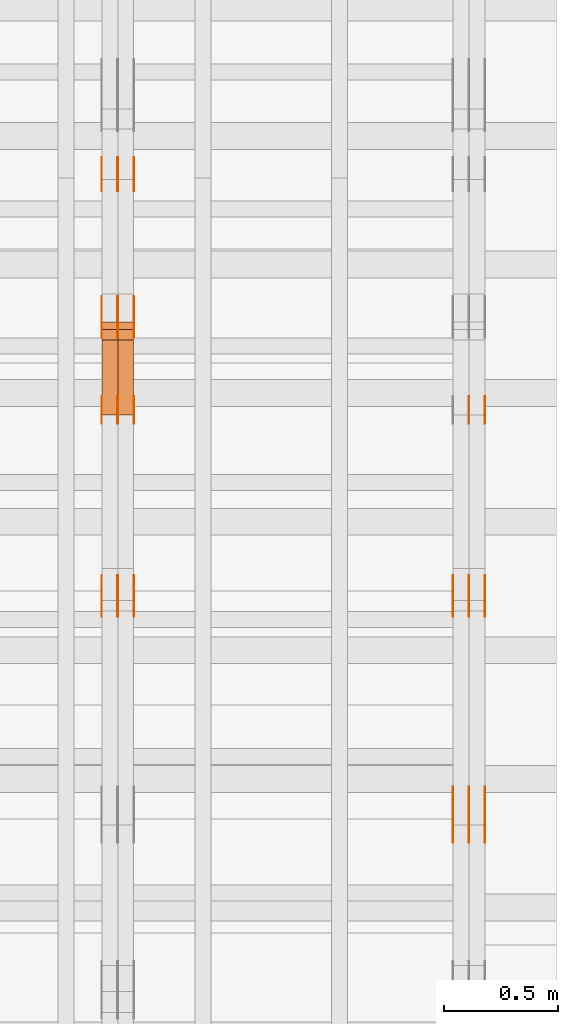
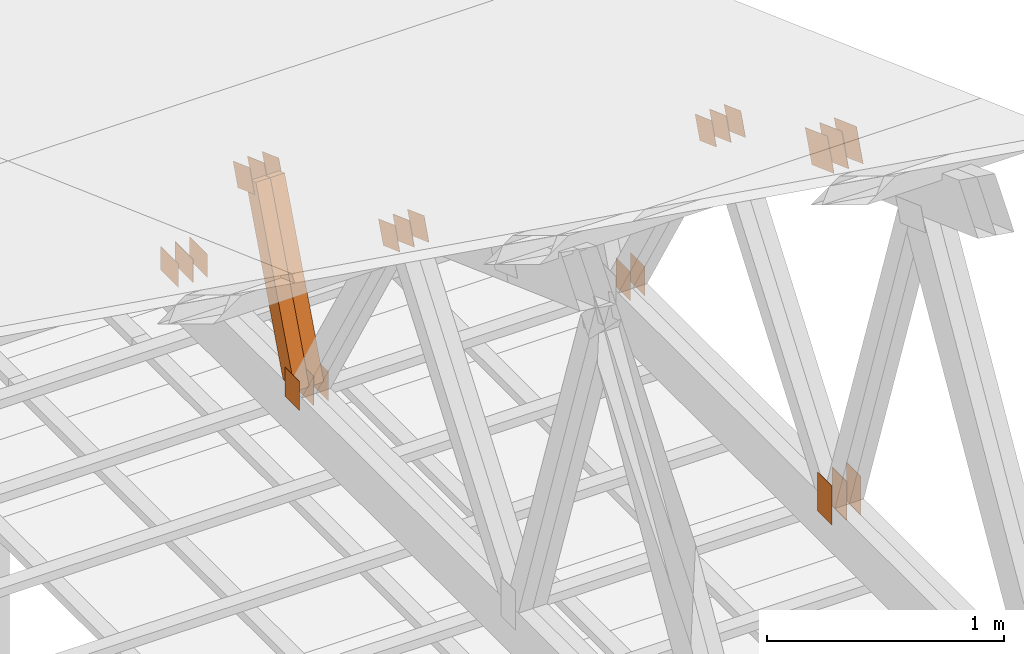
# One storey, part 176 of 189: 32 proxies.
"""IFC2X3 building model written with IfcOpenShell, lengths in millimetres."""

from ifc_helpers import new_model, entity, si_unit, converted_unit, derived_unit, direction, frame, frame_2d, origin, origin_2d_with_axis, place, context, subcontext, project, spatial, polyline, rectangle, outline, extrude, source, transform, mapped, material, type_object, type_shapes, element, save


model = new_model("IFC2X3")

# Units and contexts
model_context = context("Model", 3, precision=0.01, world=origin(), true_north=direction((6.12303176911189e-17, 1.0)))
body_context = subcontext(model_context, "Body", "Model", "MODEL_VIEW")
ifc_project = project(units=[si_unit("LENGTHUNIT", "METRE", prefix="MILLI"), si_unit("AREAUNIT", "SQUARE_METRE"), si_unit("VOLUMEUNIT", "CUBIC_METRE"), converted_unit("PLANEANGLEUNIT", "DEGREE", entity("IfcRatioMeasure", 0.0174532925199433), si_unit("PLANEANGLEUNIT", "RADIAN"), dimensions=[0, 0, 0, 0, 0, 0, 0]), si_unit("MASSUNIT", "GRAM", prefix="KILO"), derived_unit("MASSDENSITYUNIT", [(si_unit("MASSUNIT", "GRAM", prefix="KILO"), 1), (si_unit("LENGTHUNIT", "METRE"), -3)]), si_unit("TIMEUNIT", "SECOND"), si_unit("FREQUENCYUNIT", "HERTZ"), si_unit("THERMODYNAMICTEMPERATUREUNIT", "DEGREE_CELSIUS"), derived_unit("THERMALTRANSMITTANCEUNIT", [(si_unit("MASSUNIT", "GRAM", prefix="KILO"), 1), (si_unit("THERMODYNAMICTEMPERATUREUNIT", "KELVIN"), -1), (si_unit("TIMEUNIT", "SECOND"), -3)]), derived_unit("VOLUMETRICFLOWRATEUNIT", [(si_unit("LENGTHUNIT", "METRE"), 3), (si_unit("TIMEUNIT", "SECOND"), -1)]), si_unit("ELECTRICCURRENTUNIT", "AMPERE"), si_unit("ELECTRICVOLTAGEUNIT", "VOLT"), si_unit("POWERUNIT", "WATT"), si_unit("FORCEUNIT", "NEWTON"), si_unit("ILLUMINANCEUNIT", "LUX"), si_unit("LUMINOUSFLUXUNIT", "LUMEN"), si_unit("LUMINOUSINTENSITYUNIT", "CANDELA"), derived_unit("USERDEFINED", [(si_unit("MASSUNIT", "GRAM", prefix="KILO"), -1), (si_unit("LENGTHUNIT", "METRE"), -2), (si_unit("TIMEUNIT", "SECOND"), 3), (si_unit("LUMINOUSFLUXUNIT", "LUMEN"), 1)]), derived_unit("LINEARVELOCITYUNIT", [(si_unit("LENGTHUNIT", "METRE"), 1), (si_unit("TIMEUNIT", "SECOND"), -1)]), si_unit("PRESSUREUNIT", "PASCAL"), derived_unit("USERDEFINED", [(si_unit("LENGTHUNIT", "METRE"), -2), (si_unit("MASSUNIT", "GRAM", prefix="KILO"), 1), (si_unit("TIMEUNIT", "SECOND"), -2)])], contexts=[model_context])

# Site, building, storey
site_placement = place(None, origin())
site = spatial("IfcSite", under=ifc_project, at=site_placement, CompositionType="ELEMENT")
building_placement = place(site_placement, origin())
building = spatial("IfcBuilding", under=site, at=building_placement, CompositionType="ELEMENT")
storey_placement = place(building_placement, origin())
storey = spatial("IfcBuildingStorey", under=building, at=storey_placement, Name="Default", CompositionType="ELEMENT", Elevation=0.0)

# Proxies
ifc_material_1 = material(Name="IfcSurfaceStyle #279940")
building_element_proxy_type_1 = type_object("IfcBuildingElementProxyType", PredefinedType="NOTDEFINED", material=ifc_material_1)
shared_shape_1 = source(origin(), body_context, "Body", "SweptSolid", [
    extrude(rectangle(XDim=200.0, YDim=120.0, at=origin_2d_with_axis()), frame((100.0, 60.0002296775929, 0.0), z_axis=(0.0, 0.0, 1.0), x_axis=(-1.0, 0.0, 0.0)), (0.0, 0.0, 1.0), 1.3),
])
type_shapes(building_element_proxy_type_1, [shared_shape_1])
proxy_1_placement = place(building_placement, frame((49841.3, 24619.3435203224, 145.0), z_axis=(-1.0, 0.0, 0.0), x_axis=(0.0, 0.0, 1.0)))
element("IfcBuildingElementProxy", 1, at=proxy_1_placement, inside=storey, type_object=building_element_proxy_type_1, material=ifc_material_1, context=body_context, shape_type="MappedRepresentation", body=[
    mapped(shared_shape_1, transform((0.0, 0.0, 0.0), scale=1.0)),
])
ifc_material_2 = material(Name="IfcSurfaceStyle #279883")
building_element_proxy_type_2 = type_object("IfcBuildingElementProxyType", PredefinedType="NOTDEFINED", material=ifc_material_2)
shared_shape_2 = source(origin(), body_context, "Body", "SweptSolid", [
    extrude(rectangle(XDim=200.0, YDim=120.0, at=origin_2d_with_axis()), frame((100.0, 60.0002296775929, 0.0), z_axis=(0.0, 0.0, 1.0), x_axis=(-1.0, 0.0, 0.0)), (0.0, 0.0, 1.0), 1.29999999999998),
])
type_shapes(building_element_proxy_type_2, [shared_shape_2])
proxy_2_placement = place(building_placement, frame((49770.0, 24619.3435203224, 145.0), z_axis=(-1.0, 0.0, 0.0), x_axis=(0.0, 0.0, 1.0)))
element("IfcBuildingElementProxy", 2, at=proxy_2_placement, inside=storey, type_object=building_element_proxy_type_2, material=ifc_material_2, context=body_context, shape_type="MappedRepresentation", body=[
    mapped(shared_shape_2, transform((0.0, 0.0, 0.0), scale=1.0)),
])
ifc_material_3 = material(Name="IfcSurfaceStyle #279826")
building_element_proxy_type_3 = type_object("IfcBuildingElementProxyType", PredefinedType="NOTDEFINED", material=ifc_material_3)
shared_shape_3 = source(origin(), body_context, "Body", "SweptSolid", [
    extrude(rectangle(XDim=200.0, YDim=120.0, at=origin_2d_with_axis()), frame((100.0, 60.0002296775929, 0.0), z_axis=(0.0, 0.0, 1.0), x_axis=(-1.0, 0.0, 0.0)), (0.0, 0.0, 1.0), 1.29999999999998),
])
type_shapes(building_element_proxy_type_3, [shared_shape_3])
proxy_3_placement = place(building_placement, frame((49771.3, 24619.3435203224, 145.0), z_axis=(-1.0, 0.0, 0.0), x_axis=(0.0, 0.0, 1.0)))
element("IfcBuildingElementProxy", 3, at=proxy_3_placement, inside=storey, type_object=building_element_proxy_type_3, material=ifc_material_3, context=body_context, shape_type="MappedRepresentation", body=[
    mapped(shared_shape_3, transform((0.0, 0.0, 0.0), scale=1.0)),
])
ifc_material_4 = material(Name="IfcSurfaceStyle #279769")
building_element_proxy_type_4 = type_object("IfcBuildingElementProxyType", PredefinedType="NOTDEFINED", material=ifc_material_4)
shared_shape_4 = source(origin(), body_context, "Body", "SweptSolid", [
    extrude(rectangle(XDim=200.0, YDim=120.0, at=origin_2d_with_axis()), frame((100.0, 60.0002296775929, 0.0), z_axis=(0.0, 0.0, 1.0), x_axis=(-1.0, 0.0, 0.0)), (0.0, 0.0, 1.0), 1.29999999999999),
])
type_shapes(building_element_proxy_type_4, [shared_shape_4])
proxy_4_placement = place(building_placement, frame((49700.0, 24619.3435203224, 145.0), z_axis=(-1.0, 0.0, 0.0), x_axis=(0.0, 0.0, 1.0)))
element("IfcBuildingElementProxy", 4, at=proxy_4_placement, inside=storey, type_object=building_element_proxy_type_4, material=ifc_material_4, context=body_context, shape_type="MappedRepresentation", body=[
    mapped(shared_shape_4, transform((0.0, 0.0, 0.0), scale=1.0)),
])
ifc_material_5 = material(Name="IfcSurfaceStyle #279256")
building_element_proxy_type_5 = type_object("IfcBuildingElementProxyType", PredefinedType="NOTDEFINED", material=ifc_material_5)
shared_shape_5 = source(origin(), body_context, "Body", "SweptSolid", [
    extrude(outline(polyline([(-74.9999475298494, -60.0), (75.0000042257432, -60.0), (74.9999684051025, 60.0), (-75.0000251009963, 60.0), (-74.9999475298494, -60.0)])), frame((75.0000607644577, 60.0000865490217, 0.0), z_axis=(0.0, 0.0, 1.0), x_axis=(-1.0, 0.0, 0.0)), (0.0, 0.0, 1.0), 1.3),
])
type_shapes(building_element_proxy_type_5, [shared_shape_5])
proxy_5_placement = place(building_placement, frame((49841.3, 25732.0586805394, 1446.84420669249), z_axis=(-1.0, 0.0, 0.0), x_axis=(0.0, -0.939692620785908, 0.342020143325669)))
element("IfcBuildingElementProxy", 5, at=proxy_5_placement, inside=storey, type_object=building_element_proxy_type_5, material=ifc_material_5, context=body_context, shape_type="MappedRepresentation", body=[
    mapped(shared_shape_5, transform((0.0, 0.0, 0.0), scale=1.0)),
])
ifc_material_6 = material(Name="IfcSurfaceStyle #279199")
building_element_proxy_type_6 = type_object("IfcBuildingElementProxyType", PredefinedType="NOTDEFINED", material=ifc_material_6)
shared_shape_6 = source(origin(), body_context, "Body", "SweptSolid", [
    extrude(outline(polyline([(-74.9999475298494, -60.0), (75.0000042257432, -60.0), (74.9999684051025, 60.0), (-75.0000251009963, 60.0), (-74.9999475298494, -60.0)])), frame((75.0000607644577, 60.0000865490217, 0.0), z_axis=(0.0, 0.0, 1.0), x_axis=(-1.0, 0.0, 0.0)), (0.0, 0.0, 1.0), 1.29999999999999),
])
type_shapes(building_element_proxy_type_6, [shared_shape_6])
proxy_6_placement = place(building_placement, frame((49770.0, 25732.0586805394, 1446.84420669249), z_axis=(-1.0, 0.0, 0.0), x_axis=(0.0, -0.939692620785908, 0.342020143325669)))
element("IfcBuildingElementProxy", 6, at=proxy_6_placement, inside=storey, type_object=building_element_proxy_type_6, material=ifc_material_6, context=body_context, shape_type="MappedRepresentation", body=[
    mapped(shared_shape_6, transform((0.0, 0.0, 0.0), scale=1.0)),
])
ifc_material_7 = material(Name="IfcSurfaceStyle #279142")
building_element_proxy_type_7 = type_object("IfcBuildingElementProxyType", PredefinedType="NOTDEFINED", material=ifc_material_7)
shared_shape_7 = source(origin(), body_context, "Body", "SweptSolid", [
    extrude(outline(polyline([(-74.9999475298494, -60.0), (75.0000042257432, -60.0), (74.9999684051025, 60.0), (-75.0000251009963, 60.0), (-74.9999475298494, -60.0)])), frame((75.0000607644577, 60.0000865490217, 0.0), z_axis=(0.0, 0.0, 1.0), x_axis=(-1.0, 0.0, 0.0)), (0.0, 0.0, 1.0), 1.29999999999999),
])
type_shapes(building_element_proxy_type_7, [shared_shape_7])
proxy_7_placement = place(building_placement, frame((49771.3, 25732.0586805394, 1446.84420669249), z_axis=(-1.0, 0.0, 0.0), x_axis=(0.0, -0.939692620785908, 0.342020143325669)))
element("IfcBuildingElementProxy", 7, at=proxy_7_placement, inside=storey, type_object=building_element_proxy_type_7, material=ifc_material_7, context=body_context, shape_type="MappedRepresentation", body=[
    mapped(shared_shape_7, transform((0.0, 0.0, 0.0), scale=1.0)),
])
ifc_material_8 = material(Name="IfcSurfaceStyle #279085")
building_element_proxy_type_8 = type_object("IfcBuildingElementProxyType", PredefinedType="NOTDEFINED", material=ifc_material_8)
shared_shape_8 = source(origin(), body_context, "Body", "SweptSolid", [
    extrude(outline(polyline([(-74.9999475298494, -60.0), (75.0000042257432, -60.0), (74.9999684051025, 60.0), (-75.0000251009963, 60.0), (-74.9999475298494, -60.0)])), frame((75.0000607644577, 60.0000865490217, 0.0), z_axis=(0.0, 0.0, 1.0), x_axis=(-1.0, 0.0, 0.0)), (0.0, 0.0, 1.0), 1.29999999999999),
])
type_shapes(building_element_proxy_type_8, [shared_shape_8])
proxy_8_placement = place(building_placement, frame((49700.0, 25732.0586805394, 1446.84420669249), z_axis=(-1.0, 0.0, 0.0), x_axis=(0.0, -0.939692620785908, 0.342020143325669)))
element("IfcBuildingElementProxy", 8, at=proxy_8_placement, inside=storey, type_object=building_element_proxy_type_8, material=ifc_material_8, context=body_context, shape_type="MappedRepresentation", body=[
    mapped(shared_shape_8, transform((0.0, 0.0, 0.0), scale=1.0)),
])
ifc_material_9 = material(Name="IfcSurfaceStyle #279028")
building_element_proxy_type_9 = type_object("IfcBuildingElementProxyType", PredefinedType="NOTDEFINED", material=ifc_material_9)
shared_shape_9 = source(origin(), body_context, "Body", "SweptSolid", [
    extrude(rectangle(XDim=150.0, YDim=120.0, at=frame_2d((-7.105427357601e-15, 0.0), x_axis=(1.0, 0.0))), frame((75.0, 60.0, 0.0), z_axis=(0.0, 0.0, 1.0), x_axis=(-1.0, 0.0, 0.0)), (0.0, 0.0, 1.0), 1.3),
])
type_shapes(building_element_proxy_type_9, [shared_shape_9])
proxy_9_placement = place(building_placement, frame((49841.3, 26439.0083007813, 170.0), z_axis=(-1.0, 0.0, 0.0), x_axis=(0.0, 0.0, 1.0)))
element("IfcBuildingElementProxy", 9, at=proxy_9_placement, inside=storey, type_object=building_element_proxy_type_9, material=ifc_material_9, context=body_context, shape_type="MappedRepresentation", body=[
    mapped(shared_shape_9, transform((0.0, 0.0, 0.0), scale=1.0)),
])
ifc_material_10 = material(Name="IfcSurfaceStyle #278971")
building_element_proxy_type_10 = type_object("IfcBuildingElementProxyType", PredefinedType="NOTDEFINED", material=ifc_material_10)
shared_shape_10 = source(origin(), body_context, "Body", "SweptSolid", [
    extrude(rectangle(XDim=150.0, YDim=120.0, at=frame_2d((-7.105427357601e-15, 0.0), x_axis=(1.0, 0.0))), frame((75.0, 60.0, 0.0), z_axis=(0.0, 0.0, 1.0), x_axis=(-1.0, 0.0, 0.0)), (0.0, 0.0, 1.0), 1.29999999999999),
])
type_shapes(building_element_proxy_type_10, [shared_shape_10])
proxy_10_placement = place(building_placement, frame((49770.0, 26439.0083007813, 170.0), z_axis=(-1.0, 0.0, 0.0), x_axis=(0.0, 0.0, 1.0)))
element("IfcBuildingElementProxy", 10, at=proxy_10_placement, inside=storey, type_object=building_element_proxy_type_10, material=ifc_material_10, context=body_context, shape_type="MappedRepresentation", body=[
    mapped(shared_shape_10, transform((0.0, 0.0, 0.0), scale=1.0)),
])
ifc_material_11 = material(Name="IfcSurfaceStyle #274132")
building_element_proxy_type_11 = type_object("IfcBuildingElementProxyType", PredefinedType="NOTDEFINED", material=ifc_material_11)
shared_shape_11 = source(origin(), body_context, "Body", "SweptSolid", [
    extrude(outline(polyline([(-99.9999065788418, -84.0000755647729), (99.9999734279406, -84.0000755647729), (99.9999483293475, 84.000075564773), (-100.000015178446, 84.000075564773), (-99.9999065788418, -84.0000755647729)])), frame((100.000157783747, 84.0001144608011, 0.0), z_axis=(0.0, 0.0, 1.0), x_axis=(-1.0, 0.0, 0.0)), (0.0, 0.0, 1.0), 1.3),
])
type_shapes(building_element_proxy_type_11, [shared_shape_11])
proxy_11_placement = place(building_placement, frame((49841.3, 24788.4767593228, 1895.10136879206), z_axis=(-1.0, 0.0, 0.0), x_axis=(0.0, -0.939692620785908, 0.342020143325669)))
element("IfcBuildingElementProxy", 11, at=proxy_11_placement, inside=storey, type_object=building_element_proxy_type_11, material=ifc_material_11, context=body_context, shape_type="MappedRepresentation", body=[
    mapped(shared_shape_11, transform((0.0, 0.0, 0.0), scale=1.0)),
])
ifc_material_12 = material(Name="IfcSurfaceStyle #274075")
building_element_proxy_type_12 = type_object("IfcBuildingElementProxyType", PredefinedType="NOTDEFINED", material=ifc_material_12)
shared_shape_12 = source(origin(), body_context, "Body", "SweptSolid", [
    extrude(outline(polyline([(-99.9999065788418, -84.0000755647729), (99.9999734279406, -84.0000755647729), (99.9999483293475, 84.000075564773), (-100.000015178446, 84.000075564773), (-99.9999065788418, -84.0000755647729)])), frame((100.000157783747, 84.0001144608011, 0.0), z_axis=(0.0, 0.0, 1.0), x_axis=(-1.0, 0.0, 0.0)), (0.0, 0.0, 1.0), 1.29999999999998),
])
type_shapes(building_element_proxy_type_12, [shared_shape_12])
proxy_12_placement = place(building_placement, frame((49770.0, 24788.4767593228, 1895.10136879206), z_axis=(-1.0, 0.0, 0.0), x_axis=(0.0, -0.939692620785908, 0.342020143325669)))
element("IfcBuildingElementProxy", 12, at=proxy_12_placement, inside=storey, type_object=building_element_proxy_type_12, material=ifc_material_12, context=body_context, shape_type="MappedRepresentation", body=[
    mapped(shared_shape_12, transform((0.0, 0.0, 0.0), scale=1.0)),
])
ifc_material_13 = material(Name="IfcSurfaceStyle #274018")
building_element_proxy_type_13 = type_object("IfcBuildingElementProxyType", PredefinedType="NOTDEFINED", material=ifc_material_13)
shared_shape_13 = source(origin(), body_context, "Body", "SweptSolid", [
    extrude(outline(polyline([(-99.9999065788418, -84.0000755647729), (99.9999734279406, -84.0000755647729), (99.9999483293475, 84.000075564773), (-100.000015178446, 84.000075564773), (-99.9999065788418, -84.0000755647729)])), frame((100.000157783747, 84.0001144608011, 0.0), z_axis=(0.0, 0.0, 1.0), x_axis=(-1.0, 0.0, 0.0)), (0.0, 0.0, 1.0), 1.29999999999998),
])
type_shapes(building_element_proxy_type_13, [shared_shape_13])
proxy_13_placement = place(building_placement, frame((49771.3, 24788.4767593228, 1895.10136879206), z_axis=(-1.0, 0.0, 0.0), x_axis=(0.0, -0.939692620785908, 0.342020143325669)))
element("IfcBuildingElementProxy", 13, at=proxy_13_placement, inside=storey, type_object=building_element_proxy_type_13, material=ifc_material_13, context=body_context, shape_type="MappedRepresentation", body=[
    mapped(shared_shape_13, transform((0.0, 0.0, 0.0), scale=1.0)),
])
ifc_material_14 = material(Name="IfcSurfaceStyle #273961")
building_element_proxy_type_14 = type_object("IfcBuildingElementProxyType", PredefinedType="NOTDEFINED", material=ifc_material_14)
shared_shape_14 = source(origin(), body_context, "Body", "SweptSolid", [
    extrude(outline(polyline([(-99.9999065788418, -84.0000755647729), (99.9999734279406, -84.0000755647729), (99.9999483293475, 84.000075564773), (-100.000015178446, 84.000075564773), (-99.9999065788418, -84.0000755647729)])), frame((100.000157783747, 84.0001144608011, 0.0), z_axis=(0.0, 0.0, 1.0), x_axis=(-1.0, 0.0, 0.0)), (0.0, 0.0, 1.0), 1.29999999999999),
])
type_shapes(building_element_proxy_type_14, [shared_shape_14])
proxy_14_placement = place(building_placement, frame((49700.0, 24788.4767593228, 1895.10136879206), z_axis=(-1.0, 0.0, 0.0), x_axis=(0.0, -0.939692620785908, 0.342020143325669)))
element("IfcBuildingElementProxy", 14, at=proxy_14_placement, inside=storey, type_object=building_element_proxy_type_14, material=ifc_material_14, context=body_context, shape_type="MappedRepresentation", body=[
    mapped(shared_shape_14, transform((0.0, 0.0, 0.0), scale=1.0)),
])
ifc_material_15 = material(Name="IfcSurfaceStyle #263466")
building_element_proxy_type_15 = type_object("IfcBuildingElementProxyType", PredefinedType="NOTDEFINED", material=ifc_material_15)
shared_shape_15 = source(origin(), body_context, "Body", "SweptSolid", [
    extrude(outline(polyline([(-74.9999475298494, -60.0), (75.0000042257432, -60.0), (74.9999684051025, 60.0), (-75.0000251009963, 60.0), (-74.9999475298494, -60.0)])), frame((75.0000607644577, 60.0000865490217, 0.0), z_axis=(0.0, 0.0, 1.0), x_axis=(-1.0, 0.0, 0.0)), (0.0, 0.0, 1.0), 1.3),
])
type_shapes(building_element_proxy_type_15, [shared_shape_15])
proxy_15_placement = place(building_placement, frame((48301.3, 25732.0586805394, 1446.84420669249), z_axis=(-1.0, 0.0, 0.0), x_axis=(0.0, -0.939692620785908, 0.342020143325669)))
element("IfcBuildingElementProxy", 15, at=proxy_15_placement, inside=storey, type_object=building_element_proxy_type_15, material=ifc_material_15, context=body_context, shape_type="MappedRepresentation", body=[
    mapped(shared_shape_15, transform((0.0, 0.0, 0.0), scale=1.0)),
])
ifc_material_16 = material(Name="IfcSurfaceStyle #263409")
building_element_proxy_type_16 = type_object("IfcBuildingElementProxyType", PredefinedType="NOTDEFINED", material=ifc_material_16)
shared_shape_16 = source(origin(), body_context, "Body", "SweptSolid", [
    extrude(outline(polyline([(-74.9999475298494, -60.0), (75.0000042257432, -60.0), (74.9999684051025, 60.0), (-75.0000251009963, 60.0), (-74.9999475298494, -60.0)])), frame((75.0000607644577, 60.0000865490217, 0.0), z_axis=(0.0, 0.0, 1.0), x_axis=(-1.0, 0.0, 0.0)), (0.0, 0.0, 1.0), 1.29999999999999),
])
type_shapes(building_element_proxy_type_16, [shared_shape_16])
proxy_16_placement = place(building_placement, frame((48230.0, 25732.0586805394, 1446.84420669249), z_axis=(-1.0, 0.0, 0.0), x_axis=(0.0, -0.939692620785908, 0.342020143325669)))
element("IfcBuildingElementProxy", 16, at=proxy_16_placement, inside=storey, type_object=building_element_proxy_type_16, material=ifc_material_16, context=body_context, shape_type="MappedRepresentation", body=[
    mapped(shared_shape_16, transform((0.0, 0.0, 0.0), scale=1.0)),
])
ifc_material_17 = material(Name="IfcSurfaceStyle #263352")
building_element_proxy_type_17 = type_object("IfcBuildingElementProxyType", PredefinedType="NOTDEFINED", material=ifc_material_17)
shared_shape_17 = source(origin(), body_context, "Body", "SweptSolid", [
    extrude(outline(polyline([(-74.9999475298494, -60.0), (75.0000042257432, -60.0), (74.9999684051025, 60.0), (-75.0000251009963, 60.0), (-74.9999475298494, -60.0)])), frame((75.0000607644577, 60.0000865490217, 0.0), z_axis=(0.0, 0.0, 1.0), x_axis=(-1.0, 0.0, 0.0)), (0.0, 0.0, 1.0), 1.29999999999999),
])
type_shapes(building_element_proxy_type_17, [shared_shape_17])
proxy_17_placement = place(building_placement, frame((48231.3, 25732.0586805394, 1446.84420669249), z_axis=(-1.0, 0.0, 0.0), x_axis=(0.0, -0.939692620785908, 0.342020143325669)))
element("IfcBuildingElementProxy", 17, at=proxy_17_placement, inside=storey, type_object=building_element_proxy_type_17, material=ifc_material_17, context=body_context, shape_type="MappedRepresentation", body=[
    mapped(shared_shape_17, transform((0.0, 0.0, 0.0), scale=1.0)),
])
ifc_material_18 = material(Name="IfcSurfaceStyle #263295")
building_element_proxy_type_18 = type_object("IfcBuildingElementProxyType", PredefinedType="NOTDEFINED", material=ifc_material_18)
shared_shape_18 = source(origin(), body_context, "Body", "SweptSolid", [
    extrude(outline(polyline([(-74.9999475298494, -60.0), (75.0000042257432, -60.0), (74.9999684051025, 60.0), (-75.0000251009963, 60.0), (-74.9999475298494, -60.0)])), frame((75.0000607644577, 60.0000865490217, 0.0), z_axis=(0.0, 0.0, 1.0), x_axis=(-1.0, 0.0, 0.0)), (0.0, 0.0, 1.0), 1.29999999999999),
])
type_shapes(building_element_proxy_type_18, [shared_shape_18])
proxy_18_placement = place(building_placement, frame((48160.0, 25732.0586805394, 1446.84420669249), z_axis=(-1.0, 0.0, 0.0), x_axis=(0.0, -0.939692620785908, 0.342020143325669)))
element("IfcBuildingElementProxy", 18, at=proxy_18_placement, inside=storey, type_object=building_element_proxy_type_18, material=ifc_material_18, context=body_context, shape_type="MappedRepresentation", body=[
    mapped(shared_shape_18, transform((0.0, 0.0, 0.0), scale=1.0)),
])
ifc_material_19 = material(Name="IfcSurfaceStyle #263238")
building_element_proxy_type_19 = type_object("IfcBuildingElementProxyType", PredefinedType="NOTDEFINED", material=ifc_material_19)
shared_shape_19 = source(origin(), body_context, "Body", "SweptSolid", [
    extrude(rectangle(XDim=150.0, YDim=120.0, at=frame_2d((-7.105427357601e-15, 0.0), x_axis=(1.0, 0.0))), frame((75.0, 60.0, 0.0), z_axis=(0.0, 0.0, 1.0), x_axis=(-1.0, 0.0, 0.0)), (0.0, 0.0, 1.0), 1.3),
])
type_shapes(building_element_proxy_type_19, [shared_shape_19])
proxy_19_placement = place(building_placement, frame((48301.3, 26439.0083007813, 170.0), z_axis=(-1.0, 0.0, 0.0), x_axis=(0.0, 0.0, 1.0)))
element("IfcBuildingElementProxy", 19, at=proxy_19_placement, inside=storey, type_object=building_element_proxy_type_19, material=ifc_material_19, context=body_context, shape_type="MappedRepresentation", body=[
    mapped(shared_shape_19, transform((0.0, 0.0, 0.0), scale=1.0)),
])
ifc_material_20 = material(Name="IfcSurfaceStyle #263181")
building_element_proxy_type_20 = type_object("IfcBuildingElementProxyType", PredefinedType="NOTDEFINED", material=ifc_material_20)
shared_shape_20 = source(origin(), body_context, "Body", "SweptSolid", [
    extrude(rectangle(XDim=150.0, YDim=120.0, at=frame_2d((-7.105427357601e-15, 0.0), x_axis=(1.0, 0.0))), frame((75.0, 60.0, 0.0), z_axis=(0.0, 0.0, 1.0), x_axis=(-1.0, 0.0, 0.0)), (0.0, 0.0, 1.0), 1.29999999999999),
])
type_shapes(building_element_proxy_type_20, [shared_shape_20])
proxy_20_placement = place(building_placement, frame((48230.0, 26439.0083007813, 170.0), z_axis=(-1.0, 0.0, 0.0), x_axis=(0.0, 0.0, 1.0)))
element("IfcBuildingElementProxy", 20, at=proxy_20_placement, inside=storey, type_object=building_element_proxy_type_20, material=ifc_material_20, context=body_context, shape_type="MappedRepresentation", body=[
    mapped(shared_shape_20, transform((0.0, 0.0, 0.0), scale=1.0)),
])
ifc_material_21 = material(Name="IfcSurfaceStyle #263124")
building_element_proxy_type_21 = type_object("IfcBuildingElementProxyType", PredefinedType="NOTDEFINED", material=ifc_material_21)
shared_shape_21 = source(origin(), body_context, "Body", "SweptSolid", [
    extrude(rectangle(XDim=150.0, YDim=120.0, at=frame_2d((-7.105427357601e-15, 0.0), x_axis=(1.0, 0.0))), frame((75.0, 60.0, 0.0), z_axis=(0.0, 0.0, 1.0), x_axis=(-1.0, 0.0, 0.0)), (0.0, 0.0, 1.0), 1.29999999999999),
])
type_shapes(building_element_proxy_type_21, [shared_shape_21])
proxy_21_placement = place(building_placement, frame((48231.3, 26439.0083007813, 170.0), z_axis=(-1.0, 0.0, 0.0), x_axis=(0.0, 0.0, 1.0)))
element("IfcBuildingElementProxy", 21, at=proxy_21_placement, inside=storey, type_object=building_element_proxy_type_21, material=ifc_material_21, context=body_context, shape_type="MappedRepresentation", body=[
    mapped(shared_shape_21, transform((0.0, 0.0, 0.0), scale=1.0)),
])
ifc_material_22 = material(Name="IfcSurfaceStyle #263067")
building_element_proxy_type_22 = type_object("IfcBuildingElementProxyType", PredefinedType="NOTDEFINED", material=ifc_material_22)
shared_shape_22 = source(origin(), body_context, "Body", "SweptSolid", [
    extrude(rectangle(XDim=150.0, YDim=120.0, at=frame_2d((-7.105427357601e-15, 0.0), x_axis=(1.0, 0.0))), frame((75.0, 60.0, 0.0), z_axis=(0.0, 0.0, 1.0), x_axis=(-1.0, 0.0, 0.0)), (0.0, 0.0, 1.0), 1.29999999999999),
])
type_shapes(building_element_proxy_type_22, [shared_shape_22])
proxy_22_placement = place(building_placement, frame((48160.0, 26439.0083007813, 170.0), z_axis=(-1.0, 0.0, 0.0), x_axis=(0.0, 0.0, 1.0)))
element("IfcBuildingElementProxy", 22, at=proxy_22_placement, inside=storey, type_object=building_element_proxy_type_22, material=ifc_material_22, context=body_context, shape_type="MappedRepresentation", body=[
    mapped(shared_shape_22, transform((0.0, 0.0, 0.0), scale=1.0)),
])
ifc_material_23 = material(Name="IfcSurfaceStyle #262554")
building_element_proxy_type_23 = type_object("IfcBuildingElementProxyType", PredefinedType="NOTDEFINED", material=ifc_material_23)
shared_shape_23 = source(origin(), body_context, "Body", "SweptSolid", [
    extrude(outline(polyline([(-74.9999684051023, -60.0), (75.0000251009964, -60.0), (74.9999475298495, 60.0), (-75.0000042257435, 60.0), (-74.9999684051023, -60.0)])), frame((75.0000251009964, 60.0000006265238, 0.0), z_axis=(0.0, 0.0, 1.0), x_axis=(-1.0, 0.0, 0.0)), (0.0, 0.0, 1.0), 1.3),
])
type_shapes(building_element_proxy_type_23, [shared_shape_23])
proxy_23_placement = place(building_placement, frame((48301.3, 26956.490053282, 1001.18769055967), z_axis=(-1.0, 0.0, 0.0), x_axis=(0.0, -0.939692620785908, 0.342020143325669)))
element("IfcBuildingElementProxy", 23, at=proxy_23_placement, inside=storey, type_object=building_element_proxy_type_23, material=ifc_material_23, context=body_context, shape_type="MappedRepresentation", body=[
    mapped(shared_shape_23, transform((0.0, 0.0, 0.0), scale=1.0)),
])
ifc_material_24 = material(Name="IfcSurfaceStyle #262497")
building_element_proxy_type_24 = type_object("IfcBuildingElementProxyType", PredefinedType="NOTDEFINED", material=ifc_material_24)
shared_shape_24 = source(origin(), body_context, "Body", "SweptSolid", [
    extrude(outline(polyline([(-74.9999684051023, -60.0), (75.0000251009964, -60.0), (74.9999475298495, 60.0), (-75.0000042257435, 60.0), (-74.9999684051023, -60.0)])), frame((75.0000251009964, 60.0000006265238, 0.0), z_axis=(0.0, 0.0, 1.0), x_axis=(-1.0, 0.0, 0.0)), (0.0, 0.0, 1.0), 1.29999999999999),
])
type_shapes(building_element_proxy_type_24, [shared_shape_24])
proxy_24_placement = place(building_placement, frame((48230.0, 26956.490053282, 1001.18769055967), z_axis=(-1.0, 0.0, 0.0), x_axis=(0.0, -0.939692620785908, 0.342020143325669)))
element("IfcBuildingElementProxy", 24, at=proxy_24_placement, inside=storey, type_object=building_element_proxy_type_24, material=ifc_material_24, context=body_context, shape_type="MappedRepresentation", body=[
    mapped(shared_shape_24, transform((0.0, 0.0, 0.0), scale=1.0)),
])
ifc_material_25 = material(Name="IfcSurfaceStyle #262440")
building_element_proxy_type_25 = type_object("IfcBuildingElementProxyType", PredefinedType="NOTDEFINED", material=ifc_material_25)
shared_shape_25 = source(origin(), body_context, "Body", "SweptSolid", [
    extrude(outline(polyline([(-74.9999684051023, -60.0), (75.0000251009964, -60.0), (74.9999475298495, 60.0), (-75.0000042257435, 60.0), (-74.9999684051023, -60.0)])), frame((75.0000251009964, 60.0000006265238, 0.0), z_axis=(0.0, 0.0, 1.0), x_axis=(-1.0, 0.0, 0.0)), (0.0, 0.0, 1.0), 1.29999999999999),
])
type_shapes(building_element_proxy_type_25, [shared_shape_25])
proxy_25_placement = place(building_placement, frame((48231.3, 26956.490053282, 1001.18769055967), z_axis=(-1.0, 0.0, 0.0), x_axis=(0.0, -0.939692620785908, 0.342020143325669)))
element("IfcBuildingElementProxy", 25, at=proxy_25_placement, inside=storey, type_object=building_element_proxy_type_25, material=ifc_material_25, context=body_context, shape_type="MappedRepresentation", body=[
    mapped(shared_shape_25, transform((0.0, 0.0, 0.0), scale=1.0)),
])
ifc_material_26 = material(Name="IfcSurfaceStyle #262383")
building_element_proxy_type_26 = type_object("IfcBuildingElementProxyType", PredefinedType="NOTDEFINED", material=ifc_material_26)
shared_shape_26 = source(origin(), body_context, "Body", "SweptSolid", [
    extrude(outline(polyline([(-74.9999684051023, -60.0), (75.0000251009964, -60.0), (74.9999475298495, 60.0), (-75.0000042257435, 60.0), (-74.9999684051023, -60.0)])), frame((75.0000251009964, 60.0000006265238, 0.0), z_axis=(0.0, 0.0, 1.0), x_axis=(-1.0, 0.0, 0.0)), (0.0, 0.0, 1.0), 1.29999999999999),
])
type_shapes(building_element_proxy_type_26, [shared_shape_26])
proxy_26_placement = place(building_placement, frame((48160.0, 26956.490053282, 1001.18769055967), z_axis=(-1.0, 0.0, 0.0), x_axis=(0.0, -0.939692620785908, 0.342020143325669)))
element("IfcBuildingElementProxy", 26, at=proxy_26_placement, inside=storey, type_object=building_element_proxy_type_26, material=ifc_material_26, context=body_context, shape_type="MappedRepresentation", body=[
    mapped(shared_shape_26, transform((0.0, 0.0, 0.0), scale=1.0)),
])
ifc_material_27 = material(Name="IfcSurfaceStyle #262326")
building_element_proxy_type_27 = type_object("IfcBuildingElementProxyType", PredefinedType="NOTDEFINED", material=ifc_material_27)
shared_shape_27 = source(origin(), body_context, "Body", "SweptSolid", [
    extrude(rectangle(XDim=150.0, YDim=120.0, at=origin_2d_with_axis()), frame((75.0, 60.0, 0.0), z_axis=(0.0, 0.0, 1.0), x_axis=(-1.0, 0.0, 0.0)), (0.0, 0.0, 1.0), 1.3),
])
type_shapes(building_element_proxy_type_27, [shared_shape_27])
proxy_27_placement = place(building_placement, frame((48301.3, 27607.3129882813, 185.0), z_axis=(-1.0, 0.0, 0.0), x_axis=(0.0, -1.0, 0.0)))
element("IfcBuildingElementProxy", 27, at=proxy_27_placement, inside=storey, type_object=building_element_proxy_type_27, material=ifc_material_27, context=body_context, shape_type="MappedRepresentation", body=[
    mapped(shared_shape_27, transform((0.0, 0.0, 0.0), scale=1.0)),
])
ifc_material_28 = material(Name="IfcSurfaceStyle #262269")
building_element_proxy_type_28 = type_object("IfcBuildingElementProxyType", PredefinedType="NOTDEFINED", material=ifc_material_28)
shared_shape_28 = source(origin(), body_context, "Body", "SweptSolid", [
    extrude(rectangle(XDim=150.0, YDim=120.0, at=origin_2d_with_axis()), frame((75.0, 60.0, 0.0), z_axis=(0.0, 0.0, 1.0), x_axis=(-1.0, 0.0, 0.0)), (0.0, 0.0, 1.0), 1.29999999999999),
])
type_shapes(building_element_proxy_type_28, [shared_shape_28])
proxy_28_placement = place(building_placement, frame((48230.0, 27607.3129882813, 185.0), z_axis=(-1.0, 0.0, 0.0), x_axis=(0.0, -1.0, 0.0)))
element("IfcBuildingElementProxy", 28, at=proxy_28_placement, inside=storey, type_object=building_element_proxy_type_28, material=ifc_material_28, context=body_context, shape_type="MappedRepresentation", body=[
    mapped(shared_shape_28, transform((0.0, 0.0, 0.0), scale=1.0)),
])
ifc_material_29 = material(Name="IfcSurfaceStyle #262212")
building_element_proxy_type_29 = type_object("IfcBuildingElementProxyType", PredefinedType="NOTDEFINED", material=ifc_material_29)
shared_shape_29 = source(origin(), body_context, "Body", "SweptSolid", [
    extrude(rectangle(XDim=150.0, YDim=120.0, at=origin_2d_with_axis()), frame((75.0, 60.0, 0.0), z_axis=(0.0, 0.0, 1.0), x_axis=(-1.0, 0.0, 0.0)), (0.0, 0.0, 1.0), 1.29999999999999),
])
type_shapes(building_element_proxy_type_29, [shared_shape_29])
proxy_29_placement = place(building_placement, frame((48231.3, 27607.3129882813, 185.0), z_axis=(-1.0, 0.0, 0.0), x_axis=(0.0, -1.0, 0.0)))
element("IfcBuildingElementProxy", 29, at=proxy_29_placement, inside=storey, type_object=building_element_proxy_type_29, material=ifc_material_29, context=body_context, shape_type="MappedRepresentation", body=[
    mapped(shared_shape_29, transform((0.0, 0.0, 0.0), scale=1.0)),
])
ifc_material_30 = material(Name="IfcSurfaceStyle #262155")
building_element_proxy_type_30 = type_object("IfcBuildingElementProxyType", PredefinedType="NOTDEFINED", material=ifc_material_30)
shared_shape_30 = source(origin(), body_context, "Body", "SweptSolid", [
    extrude(rectangle(XDim=150.0, YDim=120.0, at=origin_2d_with_axis()), frame((75.0, 60.0, 0.0), z_axis=(0.0, 0.0, 1.0), x_axis=(-1.0, 0.0, 0.0)), (0.0, 0.0, 1.0), 1.29999999999999),
])
type_shapes(building_element_proxy_type_30, [shared_shape_30])
proxy_30_placement = place(building_placement, frame((48160.0, 27607.3129882813, 185.0), z_axis=(-1.0, 0.0, 0.0), x_axis=(0.0, -1.0, 0.0)))
element("IfcBuildingElementProxy", 30, at=proxy_30_placement, inside=storey, type_object=building_element_proxy_type_30, material=ifc_material_30, context=body_context, shape_type="MappedRepresentation", body=[
    mapped(shared_shape_30, transform((0.0, 0.0, 0.0), scale=1.0)),
])
ifc_material_31 = material(Name="IfcSurfaceStyle #255078")
building_element_proxy_type_31 = type_object("IfcBuildingElementProxyType", Name="T1-W14 255076", PredefinedType="NOTDEFINED", material=ifc_material_31)
shared_shape_31 = source(origin(), body_context, "Body", "SweptSolid", [
    extrude(outline(polyline([(-561.981237417233, -47.499947472121), (373.092610496013, -47.499947472121), (373.679602940405, -4.61719047935016e-05), (341.277449358876, 47.4999705580734), (-526.068425378061, 47.4999705580734), (-561.981237417233, -47.499947472121)])), frame((373.679632439416, 47.500120814091, 0.0), z_axis=(0.0, 0.0, 1.0), x_axis=(-1.0, 0.0, 0.0)), (0.0, 0.0, 1.0), 69.9999999999999),
])
type_shapes(building_element_proxy_type_31, [shared_shape_31])
proxy_31_placement = place(building_placement, frame((48300.0, 26895.4809555667, 1086.61918844835), z_axis=(-1.0, 0.0, 0.0), x_axis=(0.0, -0.353606472447933, -0.935394281916951)))
element("IfcBuildingElementProxy", 31, at=proxy_31_placement, inside=storey, type_object=building_element_proxy_type_31, material=ifc_material_31, Name="T1-W14", context=body_context, shape_type="MappedRepresentation", body=[
    mapped(shared_shape_31, transform((0.0, 0.0, 0.0), scale=1.0)),
])
ifc_material_32 = material(Name="IfcSurfaceStyle #255012")
building_element_proxy_type_32 = type_object("IfcBuildingElementProxyType", Name="T1-W14 255010", PredefinedType="NOTDEFINED", material=ifc_material_32)
shared_shape_32 = source(origin(), body_context, "Body", "SweptSolid", [
    extrude(outline(polyline([(-561.981237417233, -47.499947472121), (373.092610496013, -47.499947472121), (373.679602940405, -4.61719047935016e-05), (341.277449358876, 47.4999705580734), (-526.068425378061, 47.4999705580734), (-561.981237417233, -47.499947472121)])), frame((373.679632439416, 47.500120814091, 0.0), z_axis=(0.0, 0.0, 1.0), x_axis=(-1.0, 0.0, 0.0)), (0.0, 0.0, 1.0), 69.9999999999999),
])
type_shapes(building_element_proxy_type_32, [shared_shape_32])
proxy_32_placement = place(building_placement, frame((48230.0, 26895.4809555667, 1086.61918844835), z_axis=(-1.0, 0.0, 0.0), x_axis=(0.0, -0.353606472447933, -0.935394281916951)))
element("IfcBuildingElementProxy", 32, at=proxy_32_placement, inside=storey, type_object=building_element_proxy_type_32, material=ifc_material_32, Name="T1-W14", context=body_context, shape_type="MappedRepresentation", body=[
    mapped(shared_shape_32, transform((0.0, 0.0, 0.0), scale=1.0)),
])

save(model, "model.ifc")
